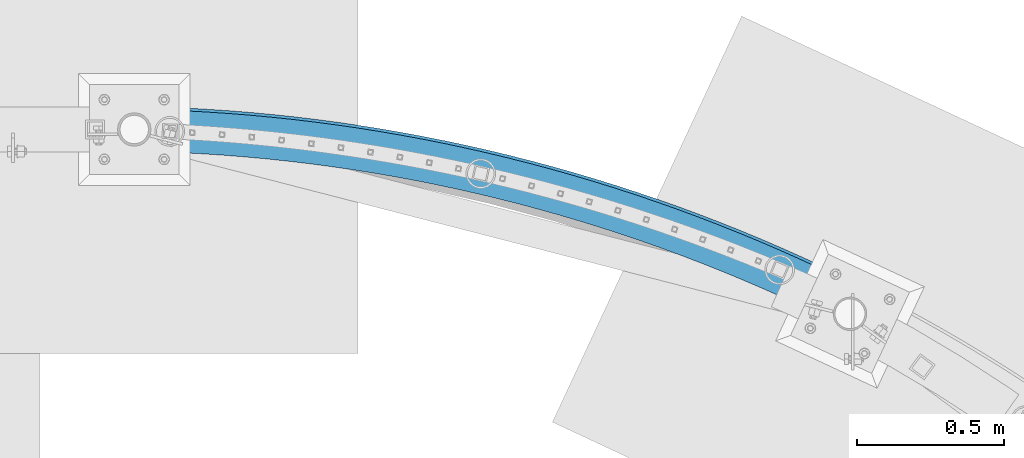
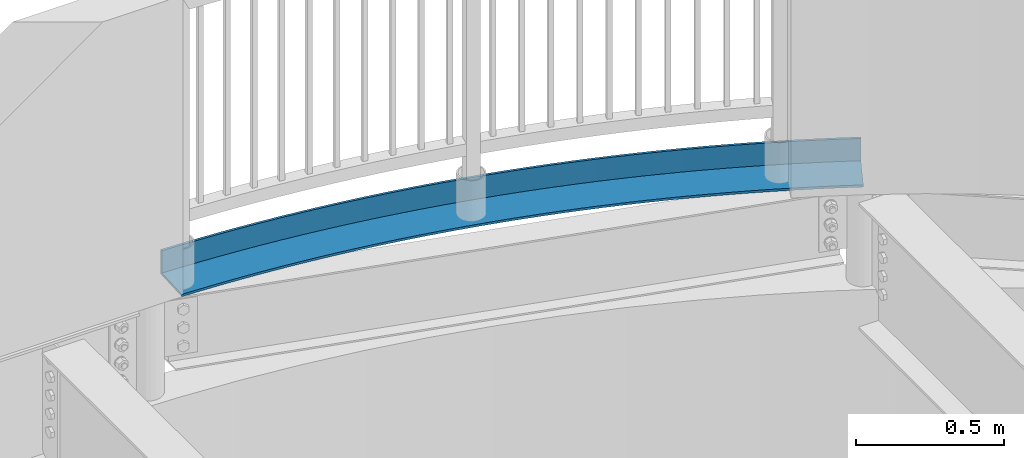
# One storey, part 330 of 975: 1 beam.
"""IFC2X3 building model written with IfcOpenShell, lengths in millimetres."""

from ifc_helpers import new_model, si_unit, frame, origin_with_axes, place, context, subcontext, project, spatial, faceted_brep, material, type_object, element, save


model = new_model("IFC2X3")

# Units and contexts
model_context = context("Model", 3, precision=1e-05, world=origin_with_axes())
body_context = subcontext(model_context, "Body", "Model", "MODEL_VIEW")
ifc_project = project(units=[si_unit("LENGTHUNIT", "METRE", prefix="MILLI"), si_unit("AREAUNIT", "SQUARE_METRE"), si_unit("VOLUMEUNIT", "CUBIC_METRE"), si_unit("MASSUNIT", "GRAM", prefix="KILO"), si_unit("TIMEUNIT", "SECOND"), si_unit("PLANEANGLEUNIT", "RADIAN"), si_unit("SOLIDANGLEUNIT", "STERADIAN"), si_unit("THERMODYNAMICTEMPERATUREUNIT", "DEGREE_CELSIUS"), si_unit("LUMINOUSINTENSITYUNIT", "LUMEN")], contexts=[model_context])

# Site, building, storey
site_placement = place(None, origin_with_axes())
site = spatial("IfcSite", under=ifc_project, at=site_placement, CompositionType="ELEMENT")
building_placement = place(site_placement, origin_with_axes())
building = spatial("IfcBuilding", under=site, at=building_placement, Name="Undefined", CompositionType="ELEMENT")
storey_placement = place(building_placement, origin_with_axes())
storey = spatial("IfcBuildingStorey", under=building, at=storey_placement, Name="Undefined", CompositionType="ELEMENT", Elevation=0.0)

# Beam
ifc_material = material(Name="STEEL/A36")
beam_type = type_object("IfcBeamType", Name="L6X4X3/8", PredefinedType="NOTDEFINED")
beam_placement = place(storey_placement, frame((20394.1373625324, 28238.9490343957, 3987.8), z_axis=(-0.406166379132024, -0.913799142297026, 0.0), x_axis=(-0.913799142297027, 0.406166379132023, 0.0)))
element("IfcBeam", 1, at=beam_placement, inside=storey, type_object=beam_type, material=ifc_material, Name="ANGLE", ObjectType="L6X4X3/8", context=body_context, shape_type="Brep", body=[
    faceted_brep([(1860.76385882529, 41.2750000000001, -473.558574170696), (1860.76385882529, -50.8000000000002, -473.558574170696), (1935.30064447676, -50.8000000000002, -476.473383915014), (1935.30064447676, 41.2750000000001, -476.473383915014), (2009.86907889182, -50.8000000000002, -478.416865323743), (2009.86907889182, 41.2750000000001, -478.416865323743), (2084.45650471413, -50.8000000000002, -479.388688507468), (2084.45650471413, 41.2750000000001, -479.388688507468), (2159.05026136372, -50.8000000000002, -479.38868850749), (2159.05026136372, 41.2750000000001, -479.38868850749), (2233.63768718603, -50.8000000000002, -478.416865323808), (2233.63768718603, 41.2750000000001, -478.416865323808), (2308.20612160109, -50.8000000000002, -476.47338391513), (2308.20612160109, 41.2750000000001, -476.47338391513), (2382.74290725256, -50.8000000000002, -473.558574170856), (2382.74290725256, 41.2750000000001, -473.558574170856), (2457.23539215622, -50.8000000000002, -469.672930855108), (2457.23539215622, 41.2750000000001, -469.672930855108), (2531.6709318475, -50.8000000000002, -464.817113522724), (2531.6709318475, 41.2750000000001, -464.817113522724), (2606.03689152783, -50.8000000000002, -458.991946407325), (2606.03689152783, 41.2750000000001, -458.991946407325), (2680.32064820923, -50.8000000000002, -452.19841828139), (2680.32064820923, 41.2750000000001, -452.19841828139), (2754.50959285698, -50.8000000000002, -444.43768228843), (2754.50959285698, 41.2750000000001, -444.43768228843), (2828.59113252989, -50.8000000000002, -435.711055747248), (2828.59113252989, 41.2750000000001, -435.711055747248), (2902.55269251787, -50.8000000000002, -426.020019928343), (2902.55269251787, 41.2750000000001, -426.020019928343), (2976.38171847634, -50.8000000000002, -415.366219802461), (2976.38171847634, 41.2750000000001, -415.366219802461), (3050.06567855725, -50.8000000000002, -403.7514637614), (3050.06567855725, 41.2750000000001, -403.7514637614), (3123.59206553625, -50.8000000000002, -391.177723311019), (3123.59206553625, 41.2750000000001, -391.177723311019), (3196.94839893567, -50.8000000000002, -377.647132736623), (3196.94839893567, 41.2750000000001, -377.647132736623), (3270.12222714299, -50.8000000000002, -363.161988740663), (3270.12222714299, 41.2750000000001, -363.161988740663), (3343.10112952441, -50.8000000000002, -347.724750052897), (3343.10112952441, 41.2750000000001, -347.724750052897), (3415.87271853309, -50.8000000000002, -331.338037013069), (3415.87271853309, 41.2750000000001, -331.338037013069), (3488.4246418119, -50.8000000000002, -314.004631126059), (3488.4246418119, 41.2750000000001, -314.004631126059), (3560.7445842901, -50.8000000000002, -295.727474589839), (3560.7445842901, 41.2750000000001, -295.727474589839), (3632.82027027368, -50.8000000000002, -276.509669795974), (3632.82027027368, 41.2750000000001, -276.509669795974), (3704.63946552912, -50.8000000000002, -256.35447880307), (3704.63946552912, 41.2750000000001, -256.35447880307), (3776.18997935999, -50.8000000000002, -235.265322783067), (3776.18997935999, 41.2750000000001, -235.265322783067), (3847.45966667628, -50.8000000000002, -213.245781440492), (3847.45966667628, 41.2750000000001, -213.245781440492), (3918.43643005585, -50.8000000000002, -190.299592404852), (3918.43643005585, 41.2750000000001, -190.299592404852), (3989.10822179792, -50.8000000000002, -166.430650596216), (3989.10822179792, 41.2750000000001, -166.430650596216), (4059.46304596804, -50.8000000000002, -141.643007564053), (4059.46304596804, 41.2750000000001, -141.643007564053), (4129.48896043432, -50.8000000000002, -115.940870799568), (4129.48896043432, 41.2750000000001, -115.940870799568), (4199.17407889446, -50.8000000000002, -89.328603021444), (4199.17407889446, 41.2750000000001, -89.328603021444), (4268.50657289342, -50.8000000000002, -61.8107214353877), (4268.50657289342, 41.2750000000001, -61.8107214353877), (1860.3296690706, -50.8000000000002, -483.073672922525), (1860.3296690706, 50.8000000000002, -483.073672922525), (1934.99045628411, 50.8000000000002, -485.993331829013), (1934.99045628411, -50.8000000000002, -485.993331829013), (2009.682944913, 50.8000000000002, -487.940046469877), (2009.682944913, -50.8000000000002, -487.940046469877), (2084.3944565438, 50.8000000000002, -488.913486406884), (2084.3944565438, -50.8000000000002, -488.913486406884), (2159.11230953404, 50.8000000000002, -488.913486406906), (2159.11230953404, -50.8000000000002, -488.913486406906), (2233.82382116484, 50.8000000000002, -487.940046469943), (2233.82382116484, -50.8000000000002, -487.940046469943), (2308.51630979374, 50.8000000000002, -485.99333182913), (2308.51630979374, -50.8000000000002, -485.99333182913), (2383.17709700724, 50.8000000000002, -483.073672922685), (2383.17709700724, -50.8000000000002, -483.073672922685), (2457.79350977293, 50.8000000000002, -479.181565337829), (2457.79350977293, -50.8000000000002, -479.181565337829), (2532.35288259053, 50.8000000000002, -474.317669726661), (2532.35288259053, -50.8000000000002, -474.317669726661), (2606.84255964184, 50.8000000000002, -468.482811694019), (2606.84255964184, -50.8000000000002, -468.482811694019), (2681.24989693893, 50.8000000000002, -461.677981657333), (2681.24989693893, -50.8000000000002, -461.677981657333), (2755.56226447031, 50.8000000000002, -453.904334678511), (2755.56226447031, -50.8000000000002, -453.904334678511), (2829.76704834482, 50.8000000000002, -445.163190267893), (2829.76704834482, -50.8000000000002, -445.163190267893), (2903.85165293271, 50.8000000000002, -435.456032160255), (2903.85165293271, -50.8000000000002, -435.456032160255), (2977.80350300363, 50.8000000000002, -424.784508062978), (2977.80350300363, -50.8000000000002, -424.784508062978), (3051.61004586118, 50.8000000000002, -413.150429376336), (3051.61004586118, -50.8000000000002, -413.150429376336), (3125.25875347363, 50.8000000000002, -400.555770886051), (3125.25875347363, -50.8000000000002, -400.555770886051), (3198.73712460042, 50.8000000000002, -387.002670428083), (3198.73712460042, -50.8000000000002, -387.002670428083), (3272.03268691418, 50.8000000000002, -372.493428525755), (3272.03268691418, -50.8000000000002, -372.493428525755), (3345.13299911777, 50.8000000000002, -357.030507999232), (3345.13299911777, -50.8000000000002, -357.030507999232), (3418.02565305607, 50.8000000000002, -340.616533547516), (3418.02565305607, -50.8000000000002, -340.616533547516), (3490.69827582221, 50.8000000000002, -323.25429130291), (3490.69827582221, -50.8000000000002, -323.25429130291), (3563.13853185773, 50.8000000000002, -304.946728358096), (3563.13853185773, -50.8000000000002, -304.946728358096), (3635.33412504644, 50.8000000000002, -285.696952265862), (3635.33412504644, -50.8000000000002, -285.696952265862), (3707.27280080158, 50.8000000000002, -265.508230511688), (3707.27280080158, -50.8000000000002, -265.508230511688), (3778.94234814593, 50.8000000000002, -244.383989959053), (3778.94234814593, -50.8000000000002, -244.383989959053), (3850.33060178455, 50.8000000000002, -222.327816267789), (3850.33060178455, -50.8000000000002, -222.327816267789), (3921.42544416968, 50.8000000000002, -199.343453285444), (3921.42544416968, -50.8000000000002, -199.343453285444), (3992.21480755763, 50.8000000000002, -175.434802411772), (3992.21480755763, -50.8000000000002, -175.434802411772), (4062.68667605718, 50.8000000000002, -150.605921936542), (4062.68667605718, -50.8000000000002, -150.605921936542), (4132.82908766914, 50.8000000000002, -124.861026350634), (4132.82908766914, -50.8000000000002, -124.861026350634), (4202.63013631683, 50.8000000000002, -98.2044856307111), (4202.63013631683, -50.8000000000002, -98.2044856307111), (4272.07797386703, 50.8000000000002, -70.6408244974082), (4272.07797386703, -50.8000000000002, -70.6408244974082), (4214.93555828925, 41.2750000000001, 70.6408244948616), (4214.93555828925, 50.8000000000002, 70.6408244948616), (4147.33321755902, 50.8000000000002, 43.8096361175558), (4147.33321755902, 41.2750000000001, 43.8096361175558), (4079.38705191206, 50.8000000000002, 17.8614624665715), (4079.38705191206, 41.2750000000001, 17.8614624665715), (4011.10859463103, 50.8000000000002, -7.19929197671445), (4011.10859463103, 41.2750000000001, -7.19929197671445), (3942.50943540222, 50.8000000000002, -31.3683733627768), (3942.50943540222, 41.2750000000001, -31.3683733627768), (3873.60121834839, 50.8000000000002, -54.641679196), (3873.60121834839, 41.2750000000001, -54.641679196), (3804.3956400522, 50.8000000000002, -77.015259031039), (3804.3956400522, 41.2750000000001, -77.015259031039), (3734.90444757086, 50.8000000000002, -98.485315143349), (3734.90444757086, 41.2750000000001, -98.485315143349), (3665.13943644215, 50.8000000000002, -119.048203173872), (3665.13943644215, 41.2750000000001, -119.048203173872), (3595.11244868223, 50.8000000000002, -138.700432747581), (3595.11244868223, 41.2750000000001, -138.700432747581), (3524.83537077558, 50.8000000000002, -157.438668065945), (3524.83537077558, 41.2750000000001, -157.438668065945), (3454.32013165731, 50.8000000000002, -175.259728473211), (3454.32013165731, 41.2750000000001, -175.259728473211), (3383.57870068842, 50.8000000000002, -192.160588996223), (3383.57870068842, 41.2750000000001, -192.160588996223), (3312.62308562401, 50.8000000000002, -208.138380857912), (3312.62308562401, 41.2750000000001, -208.138380857912), (3241.46533057511, 50.8000000000002, -223.190391964272), (3241.46533057511, 41.2750000000001, -223.190391964272), (3170.11751396431, 50.8000000000002, -237.314067364678), (3170.11751396431, 41.2750000000001, -237.314067364678), (3098.5917464755, 50.8000000000002, -250.507009685571), (3098.5917464755, 41.2750000000001, -250.507009685571), (3026.90016899825, 50.8000000000002, -262.766979537409), (3026.90016899825, 41.2750000000001, -262.766979537409), (2955.05495056694, 50.8000000000002, -274.09189589478), (2955.05495056694, 41.2750000000001, -274.09189589478), (2883.06828629519, 50.8000000000002, -284.479836449646), (2883.06828629519, 41.2750000000001, -284.479836449646), (2810.95239530586, 50.8000000000002, -293.929037937603), (2810.95239530586, 41.2750000000001, -293.929037937603), (2738.71951865693, 50.8000000000002, -302.437896437215), (2738.71951865693, 41.2750000000001, -302.437896437215), (2666.38191726373, 50.8000000000002, -310.004967642264), (2666.38191726373, 41.2750000000001, -310.004967642264), (2593.95186981768, 50.8000000000002, -316.628967106888), (2593.95186981768, 41.2750000000001, -316.628967106888), (2521.44167070214, 50.8000000000002, -322.308770463613), (2521.44167070214, 41.2750000000001, -322.308770463613), (2448.86362790557, 50.8000000000002, -327.043413614228), (2448.86362790557, 41.2750000000001, -327.043413614228), (2376.23006093228, 50.8000000000002, -330.832092893404), (2376.23006093228, 41.2750000000001, -330.832092893404), (2303.55329871133, 50.8000000000002, -333.674165205113), (2303.55329871133, 41.2750000000001, -333.674165205113), (2230.84567750384, 50.8000000000002, -335.569148131806), (2230.84567750384, 41.2750000000001, -335.569148131806), (2158.11953880894, 50.8000000000002, -336.516720016261), (2158.11953880894, 41.2750000000001, -336.516720016261), (2085.38722726899, 50.8000000000002, -336.51672001624), (2085.38722726899, 41.2750000000001, -336.51672001624), (2012.6610885741, 50.8000000000002, -335.569148131734), (2012.6610885741, 41.2750000000001, -335.569148131734), (1939.95346736661, 50.8000000000002, -333.674165205004), (1939.95346736661, 41.2750000000001, -333.674165205004), (1867.27670514566, 50.8000000000002, -330.832092893252), (1867.27670514566, 41.2750000000001, -330.832092893252), (1850.89200232762, 41.2750000000001, -329.977441433199), (1844.15917783336, 41.2750000000001, -472.692448308597), (1844.15917783336, -50.8000000000002, -472.692448308597), (1843.71032286707, -50.8000000000002, -482.206782100293), (1843.71032286707, 50.8000000000002, -482.206782100293), (1850.89200232762, 50.8000000000002, -329.977441433199)], [[[0, 1, 2, 3]], [[3, 2, 4, 5]], [[5, 4, 6, 7]], [[7, 6, 8, 9]], [[9, 8, 10, 11]], [[11, 10, 12, 13]], [[13, 12, 14, 15]], [[15, 14, 16, 17]], [[17, 16, 18, 19]], [[19, 18, 20, 21]], [[21, 20, 22, 23]], [[23, 22, 24, 25]], [[25, 24, 26, 27]], [[27, 26, 28, 29]], [[29, 28, 30, 31]], [[31, 30, 32, 33]], [[33, 32, 34, 35]], [[35, 34, 36, 37]], [[37, 36, 38, 39]], [[39, 38, 40, 41]], [[41, 40, 42, 43]], [[43, 42, 44, 45]], [[45, 44, 46, 47]], [[47, 46, 48, 49]], [[49, 48, 50, 51]], [[51, 50, 52, 53]], [[53, 52, 54, 55]], [[55, 54, 56, 57]], [[57, 56, 58, 59]], [[59, 58, 60, 61]], [[61, 60, 62, 63]], [[63, 62, 64, 65]], [[65, 64, 66, 67]], [[68, 69, 70, 71]], [[71, 70, 72, 73]], [[73, 72, 74, 75]], [[75, 74, 76, 77]], [[77, 76, 78, 79]], [[79, 78, 80, 81]], [[81, 80, 82, 83]], [[83, 82, 84, 85]], [[85, 84, 86, 87]], [[87, 86, 88, 89]], [[89, 88, 90, 91]], [[91, 90, 92, 93]], [[93, 92, 94, 95]], [[95, 94, 96, 97]], [[97, 96, 98, 99]], [[99, 98, 100, 101]], [[101, 100, 102, 103]], [[103, 102, 104, 105]], [[105, 104, 106, 107]], [[107, 106, 108, 109]], [[109, 108, 110, 111]], [[111, 110, 112, 113]], [[113, 112, 114, 115]], [[115, 114, 116, 117]], [[117, 116, 118, 119]], [[119, 118, 120, 121]], [[121, 120, 122, 123]], [[123, 122, 124, 125]], [[125, 124, 126, 127]], [[127, 126, 128, 129]], [[129, 128, 130, 131]], [[131, 130, 132, 133]], [[133, 132, 134, 135]], [[136, 67, 66, 135, 134, 137]], [[138, 139, 136, 137]], [[140, 141, 139, 138]], [[142, 143, 141, 140]], [[144, 145, 143, 142]], [[146, 147, 145, 144]], [[148, 149, 147, 146]], [[150, 151, 149, 148]], [[152, 153, 151, 150]], [[154, 155, 153, 152]], [[156, 157, 155, 154]], [[158, 159, 157, 156]], [[160, 161, 159, 158]], [[162, 163, 161, 160]], [[164, 165, 163, 162]], [[166, 167, 165, 164]], [[168, 169, 167, 166]], [[170, 171, 169, 168]], [[172, 173, 171, 170]], [[174, 175, 173, 172]], [[176, 177, 175, 174]], [[178, 179, 177, 176]], [[180, 181, 179, 178]], [[182, 183, 181, 180]], [[184, 185, 183, 182]], [[186, 187, 185, 184]], [[188, 189, 187, 186]], [[190, 191, 189, 188]], [[192, 193, 191, 190]], [[194, 195, 193, 192]], [[196, 197, 195, 194]], [[198, 199, 197, 196]], [[200, 201, 199, 198]], [[202, 203, 201, 200]], [[0, 3, 5, 7, 9, 11, 13, 15, 17, 19, 21, 23, 25, 27, 29, 31, 33, 35, 37, 39, 41, 43, 45, 47, 49, 51, 53, 55, 57, 59, 61, 63, 65, 67, 136, 139, 141, 143, 145, 147, 149, 151, 153, 155, 157, 159, 161, 163, 165, 167, 169, 171, 173, 175, 177, 179, 181, 183, 185, 187, 189, 191, 193, 195, 197, 199, 201, 203, 204, 205]], [[1, 0, 205, 206]], [[68, 71, 73, 75, 77, 79, 81, 83, 85, 87, 89, 91, 93, 95, 97, 99, 101, 103, 105, 107, 109, 111, 113, 115, 117, 119, 121, 123, 125, 127, 129, 131, 133, 135, 66, 64, 62, 60, 58, 56, 54, 52, 50, 48, 46, 44, 42, 40, 38, 36, 34, 32, 30, 28, 26, 24, 22, 20, 18, 16, 14, 12, 10, 8, 6, 4, 2, 1, 206, 207]], [[69, 68, 207, 208]], [[202, 200, 198, 196, 194, 192, 190, 188, 186, 184, 182, 180, 178, 176, 174, 172, 170, 168, 166, 164, 162, 160, 158, 156, 154, 152, 150, 148, 146, 144, 142, 140, 138, 137, 134, 132, 130, 128, 126, 124, 122, 120, 118, 116, 114, 112, 110, 108, 106, 104, 102, 100, 98, 96, 94, 92, 90, 88, 86, 84, 82, 80, 78, 76, 74, 72, 70, 69, 208, 209]], [[203, 202, 209, 204]], [[208, 207, 206, 205, 204, 209]]]),
])

save(model, "model.ifc")
